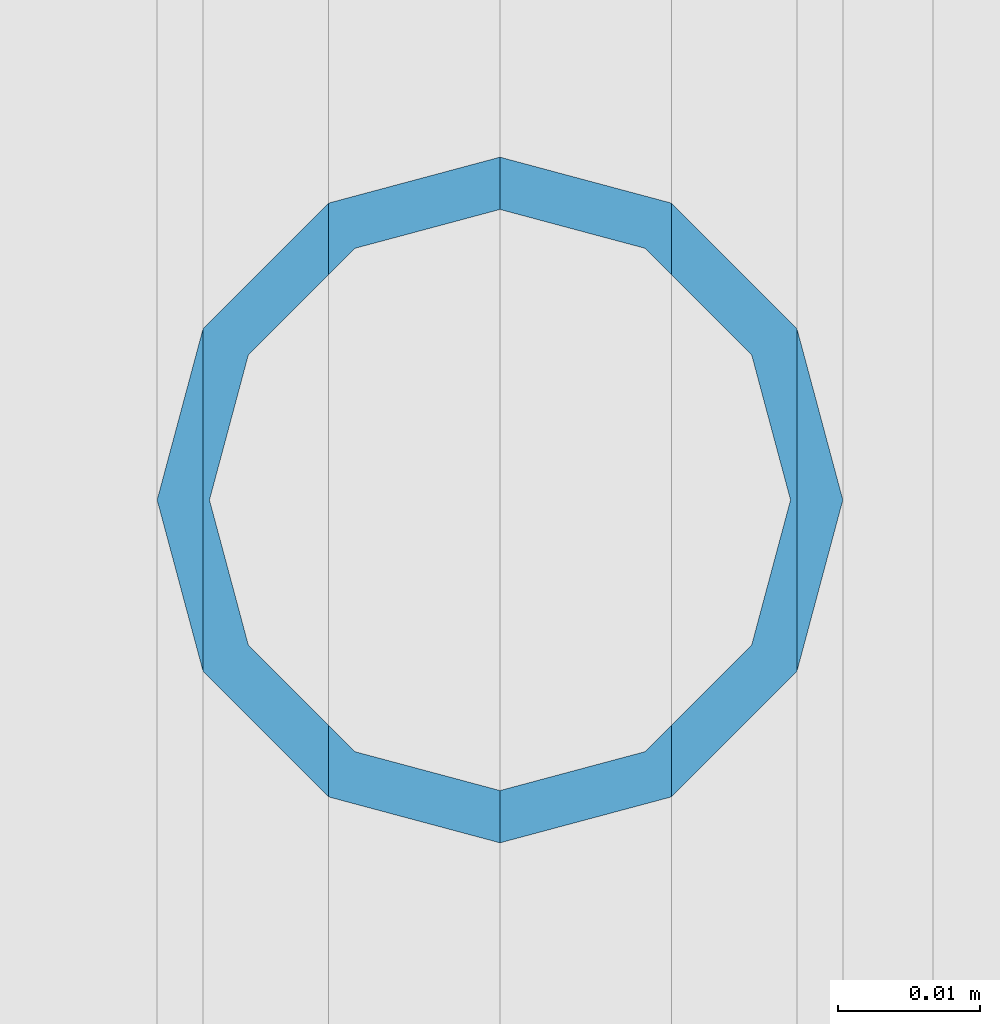
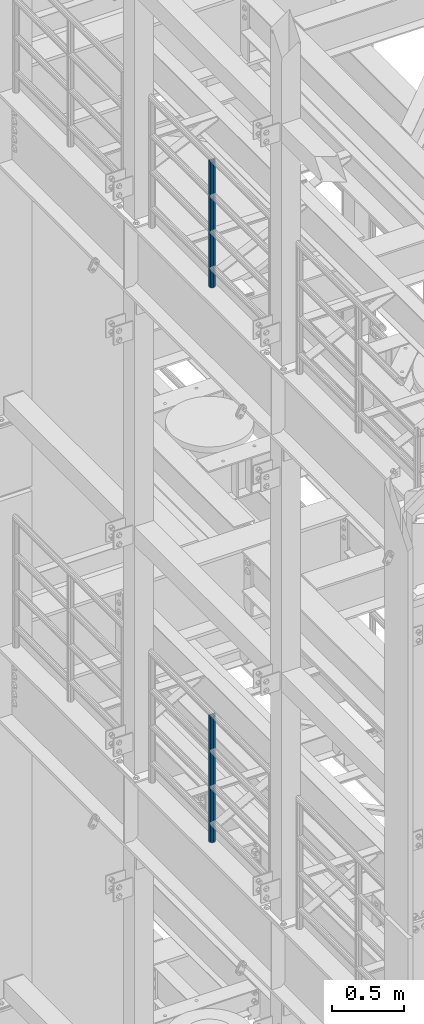
# One storey, part 676 of 1876: 2 columns, 2 elements without a shape of their own.
"""IFC2X3 building model written with IfcOpenShell, lengths in millimetres."""

from ifc_helpers import new_model, si_unit, frame, origin_with_axes, place, context, subcontext, project, spatial, faceted_brep, material, type_object, element, aggregate, save


model = new_model("IFC2X3")

# Units and contexts
model_context = context("Model", 3, precision=1e-05, world=origin_with_axes())
body_context = subcontext(model_context, "Body", "Model", "MODEL_VIEW")
ifc_project = project(units=[si_unit("LENGTHUNIT", "METRE", prefix="MILLI"), si_unit("AREAUNIT", "SQUARE_METRE"), si_unit("VOLUMEUNIT", "CUBIC_METRE"), si_unit("MASSUNIT", "GRAM", prefix="KILO"), si_unit("TIMEUNIT", "SECOND"), si_unit("PLANEANGLEUNIT", "RADIAN"), si_unit("SOLIDANGLEUNIT", "STERADIAN"), si_unit("THERMODYNAMICTEMPERATUREUNIT", "DEGREE_CELSIUS"), si_unit("LUMINOUSINTENSITYUNIT", "LUMEN")], contexts=[model_context])

# Site, building, storey
site_placement = place(None, origin_with_axes())
site = spatial("IfcSite", under=ifc_project, at=site_placement, CompositionType="ELEMENT")
building_placement = place(site_placement, origin_with_axes())
building = spatial("IfcBuilding", under=site, at=building_placement, Name="Undefined", CompositionType="ELEMENT")
storey_placement = place(building_placement, origin_with_axes())
storey = spatial("IfcBuildingStorey", under=building, at=storey_placement, Name="Undefined", CompositionType="ELEMENT", Elevation=0.0)

# Assembly, column
assembly_1_placement = place(storey_placement, origin_with_axes())
assembly_1 = element("IfcElementAssembly", 1, at=assembly_1_placement, inside=storey, Name="RAIL", AssemblyPlace="NOTDEFINED", PredefinedType="RIGID_FRAME")
ifc_material = material()
column_type = type_object("IfcColumnType", Name="PIPE1-1/2SCH40", PredefinedType="NOTDEFINED")
column_1_placement = place(assembly_1_placement, frame((-1.81898940354586e-12, -1524.0, 17983.2), z_axis=(0.0, 1.0, 0.0), x_axis=(0.0, 0.0, 1.0)))
column_1 = element("IfcColumn", 2, at=column_1_placement, type_object=column_type, material=ifc_material, Name="POST", ObjectType="PIPE1-1/2SCH40", context=body_context, shape_type="Brep", body=[
    faceted_brep([(1055.42780700668, -12.0650000000001, 20.8971929933186), (1055.42780700668, -12.0650000000001, 15.8661214311805), (1054.93437856882, -10.2235000000001, 17.7076214311801), (1052.195, 0.0, 20.4470000000001), (1052.195, 0.0, 24.1300000000001), (1054.93437856882, 10.2235000000001, 17.7076214311801), (1055.42780700668, 12.0650000000001, 15.8661214311805), (1055.42780700668, 12.0650000000001, 20.8971929933186), (1076.325, 24.1300000000001, 0.0), (1064.26, 20.8971929933184, 12.0649999999996), (1064.25999999999, 20.8971929933186, -12.0649999999996), (1061.07042843786, 17.7076214311803, 10.2235000000001), (1063.80980700668, 20.4469999999999, 0.0), (1061.07042843786, 17.7076214311803, -10.2235000000001), (1055.42780700668, 12.0650000000001, -15.8661214311805), (1055.42780700667, 12.0649999999996, -20.8971929933186), (1054.93437856882, 10.2235000000001, -17.7076214311801), (1052.195, 0.0, -20.4470000000001), (1052.19499999999, 0.0, -24.1300000000001), (1055.42780700668, -12.0650000000001, -15.8661214311805), (1055.42780700667, -12.0649999999996, -20.8971929933186), (1054.93437856882, -10.2235000000001, -17.7076214311801), (1076.325, -24.1300000000001, 0.0), (1064.25999999999, -20.8971929933186, -12.0649999999996), (1064.26, -20.8971929933184, 12.0649999999996), (1061.07042843786, -17.7076214311803, -10.2235000000001), (1063.80980700668, -20.4469999999999, 0.0), (1061.07042843786, -17.7076214311803, 10.2235000000001), (0.0, -20.8971929933184, -12.0649999999996), (0.0, -12.0650000000001, -20.8971929933186), (-1.45519152283669e-11, 0.0, -24.130000000001), (0.0, 12.0650000000001, -20.8971929933186), (0.0, 20.8971929933184, -12.0649999999996), (0.0, 24.1299999999992, 0.0), (0.0, 20.8971929933184, 12.0649999999996), (0.0, 12.0650000000001, 20.8971929933186), (-1.45519152283669e-11, 0.0, 24.130000000001), (0.0, -12.0650000000001, 20.8971929933186), (0.0, -20.8971929933184, 12.0649999999996), (0.0, -24.1299999999992, 0.0), (0.0, -17.7076214311803, -10.2235000000001), (0.0, -10.2235000000001, -17.7076214311801), (-1.45519152283669e-11, 0.0, -20.4470000000001), (0.0, 10.2235000000001, -17.7076214311801), (0.0, 17.7076214311803, -10.2235000000001), (0.0, 20.4469999999999, 0.0), (0.0, 17.7076214311803, 10.2235000000001), (0.0, 10.2235000000001, 17.7076214311801), (-1.45519152283669e-11, 0.0, 20.4470000000001), (0.0, -10.2235000000001, 17.7076214311801), (0.0, -17.7076214311803, 10.2235000000001), (0.0, -20.4469999999999, 0.0)], [[[0, 1, 2, 3, 4]], [[4, 3, 5, 6, 7]], [[8, 9, 10]], [[7, 6, 11, 12, 13, 14, 15, 10, 9]], [[16, 17, 18, 15, 14]], [[19, 20, 18, 17, 21]], [[22, 23, 24]], [[24, 23, 20, 19, 25, 26, 27, 1, 0]], [[28, 29, 20, 23]], [[29, 30, 18, 20]], [[30, 31, 15, 18]], [[31, 32, 10, 15]], [[32, 33, 8, 10]], [[33, 34, 9, 8]], [[34, 35, 7, 9]], [[35, 36, 4, 7]], [[36, 37, 0, 4]], [[37, 38, 24, 0]], [[38, 39, 22, 24]], [[39, 28, 23, 22]], [[38, 37, 36, 35, 34, 33, 32, 31, 30, 29, 28, 39], [40, 41, 42, 43, 44, 45, 46, 47, 48, 49, 50, 51]], [[40, 51, 26, 25]], [[21, 41, 40, 25, 19]], [[42, 41, 21, 17]], [[43, 42, 17, 16]], [[44, 43, 16, 14, 13]], [[45, 44, 13, 12]], [[46, 45, 12, 11]], [[5, 47, 46, 11, 6]], [[48, 47, 5, 3]], [[49, 48, 3, 2]], [[50, 49, 2, 1, 27]], [[51, 50, 27, 26]]]),
])
aggregate(assembly_1, [column_1])

assembly_2_placement = place(storey_placement, origin_with_axes())
assembly_2 = element("IfcElementAssembly", 3, at=assembly_2_placement, inside=storey, Name="RAIL", AssemblyPlace="NOTDEFINED", PredefinedType="RIGID_FRAME")
column_2_placement = place(assembly_2_placement, frame((-1.81898940354586e-12, -1524.0, 13309.6), z_axis=(0.0, 1.0, 0.0), x_axis=(0.0, 0.0, 1.0)))
column_2 = element("IfcColumn", 4, at=column_2_placement, type_object=column_type, material=ifc_material, Name="POST", ObjectType="PIPE1-1/2SCH40", context=body_context, shape_type="Brep", body=[
    faceted_brep([(1055.42780700668, -12.0650000000001, 20.8971929933186), (1055.42780700668, -12.0650000000001, 15.8661214311805), (1054.93437856882, -10.2235000000001, 17.7076214311801), (1052.195, 0.0, 20.4470000000001), (1052.195, 0.0, 24.1300000000001), (1054.93437856882, 10.2235000000001, 17.7076214311801), (1055.42780700668, 12.0650000000001, 15.8661214311805), (1055.42780700668, 12.0650000000001, 20.8971929933186), (1076.325, 24.1300000000001, 0.0), (1064.26, 20.8971929933184, 12.0649999999996), (1064.25999999999, 20.8971929933186, -12.0649999999996), (1061.07042843786, 17.7076214311803, 10.2235000000001), (1063.80980700668, 20.4469999999999, 0.0), (1061.07042843786, 17.7076214311803, -10.2235000000001), (1055.42780700668, 12.0650000000001, -15.8661214311805), (1055.42780700667, 12.0649999999996, -20.8971929933186), (1054.93437856882, 10.2235000000001, -17.7076214311801), (1052.195, 0.0, -20.4470000000001), (1052.19499999999, 0.0, -24.1300000000001), (1055.42780700668, -12.0650000000001, -15.8661214311805), (1055.42780700667, -12.0649999999996, -20.8971929933186), (1054.93437856882, -10.2235000000001, -17.7076214311801), (1076.325, -24.1300000000001, 0.0), (1064.25999999999, -20.8971929933186, -12.0649999999996), (1064.26, -20.8971929933184, 12.0649999999996), (1061.07042843786, -17.7076214311803, -10.2235000000001), (1063.80980700668, -20.4469999999999, 0.0), (1061.07042843786, -17.7076214311803, 10.2235000000001), (0.0, -20.8971929933184, -12.0649999999996), (0.0, -12.0650000000001, -20.8971929933186), (-1.45519152283669e-11, 0.0, -24.130000000001), (0.0, 12.0650000000001, -20.8971929933186), (0.0, 20.8971929933184, -12.0649999999996), (0.0, 24.1299999999992, 0.0), (0.0, 20.8971929933184, 12.0649999999996), (0.0, 12.0650000000001, 20.8971929933186), (-1.45519152283669e-11, 0.0, 24.130000000001), (0.0, -12.0650000000001, 20.8971929933186), (0.0, -20.8971929933184, 12.0649999999996), (0.0, -24.1299999999992, 0.0), (0.0, -17.7076214311803, -10.2235000000001), (0.0, -10.2235000000001, -17.7076214311801), (-1.45519152283669e-11, 0.0, -20.4470000000001), (0.0, 10.2235000000001, -17.7076214311801), (0.0, 17.7076214311803, -10.2235000000001), (0.0, 20.4469999999999, 0.0), (0.0, 17.7076214311803, 10.2235000000001), (0.0, 10.2235000000001, 17.7076214311801), (-1.45519152283669e-11, 0.0, 20.4470000000001), (0.0, -10.2235000000001, 17.7076214311801), (0.0, -17.7076214311803, 10.2235000000001), (0.0, -20.4469999999999, 0.0)], [[[0, 1, 2, 3, 4]], [[4, 3, 5, 6, 7]], [[8, 9, 10]], [[7, 6, 11, 12, 13, 14, 15, 10, 9]], [[16, 17, 18, 15, 14]], [[19, 20, 18, 17, 21]], [[22, 23, 24]], [[24, 23, 20, 19, 25, 26, 27, 1, 0]], [[28, 29, 20, 23]], [[29, 30, 18, 20]], [[30, 31, 15, 18]], [[31, 32, 10, 15]], [[32, 33, 8, 10]], [[33, 34, 9, 8]], [[34, 35, 7, 9]], [[35, 36, 4, 7]], [[36, 37, 0, 4]], [[37, 38, 24, 0]], [[38, 39, 22, 24]], [[39, 28, 23, 22]], [[38, 37, 36, 35, 34, 33, 32, 31, 30, 29, 28, 39], [40, 41, 42, 43, 44, 45, 46, 47, 48, 49, 50, 51]], [[40, 51, 26, 25]], [[21, 41, 40, 25, 19]], [[42, 41, 21, 17]], [[43, 42, 17, 16]], [[44, 43, 16, 14, 13]], [[45, 44, 13, 12]], [[46, 45, 12, 11]], [[5, 47, 46, 11, 6]], [[48, 47, 5, 3]], [[49, 48, 3, 2]], [[50, 49, 2, 1, 27]], [[51, 50, 27, 26]]]),
])
aggregate(assembly_2, [column_2])

save(model, "model.ifc")
